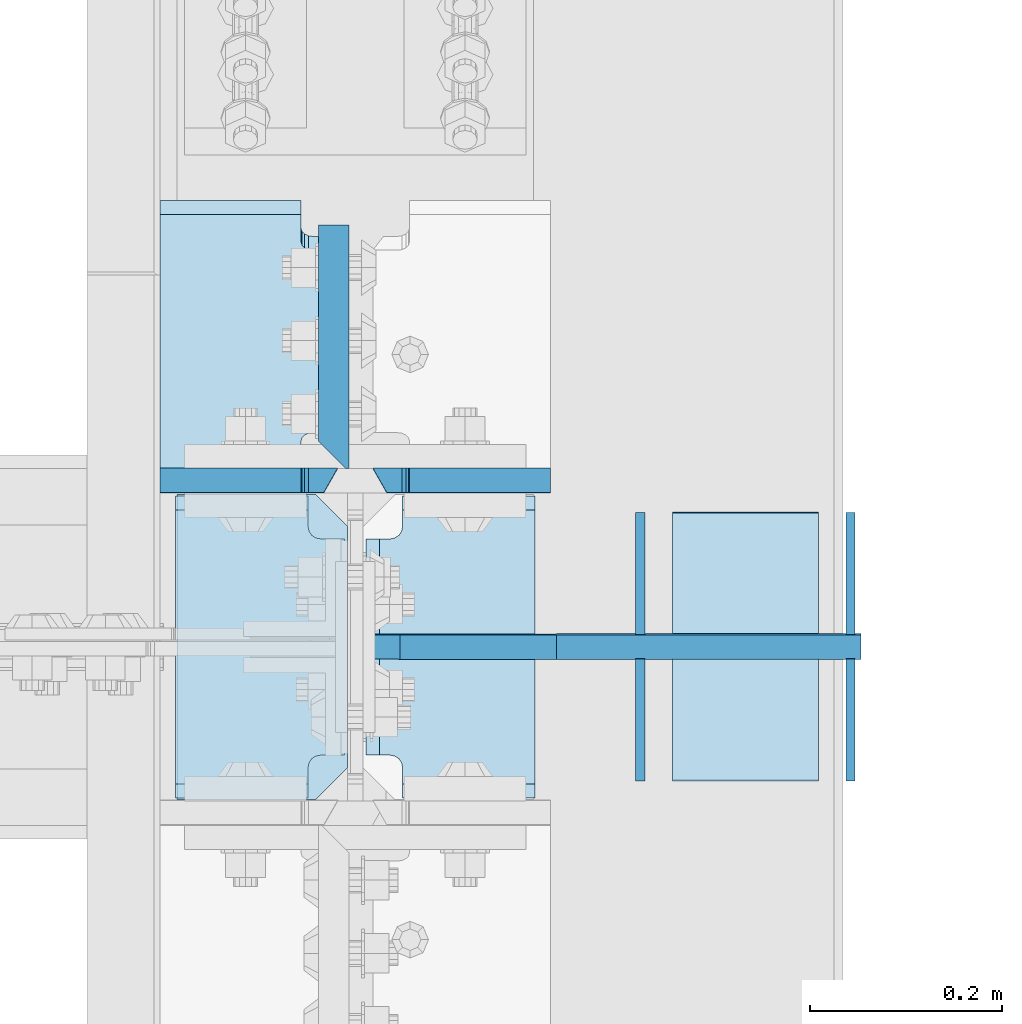
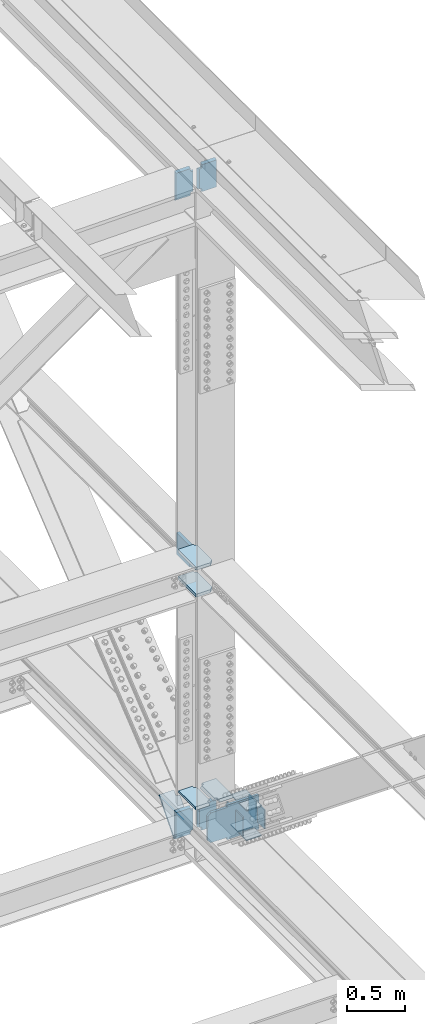
# One storey, part 3607 of 3843: 19 plates, 11 elements without a shape of their own.
"""IFC2X3 building model written with IfcOpenShell, lengths in millimetres."""

from ifc_helpers import new_model, si_unit, frame, origin_with_axes, place, context, subcontext, project, spatial, faceted_brep, material, type_object, element, aggregate, save


model = new_model("IFC2X3")

# Units and contexts
model_context = context("Model", 3, precision=1e-05, world=origin_with_axes())
body_context = subcontext(model_context, "Body", "Model", "MODEL_VIEW")
ifc_project = project(units=[si_unit("LENGTHUNIT", "METRE", prefix="MILLI"), si_unit("AREAUNIT", "SQUARE_METRE"), si_unit("VOLUMEUNIT", "CUBIC_METRE"), si_unit("MASSUNIT", "GRAM", prefix="KILO"), si_unit("TIMEUNIT", "SECOND"), si_unit("PLANEANGLEUNIT", "RADIAN"), si_unit("SOLIDANGLEUNIT", "STERADIAN"), si_unit("THERMODYNAMICTEMPERATUREUNIT", "DEGREE_CELSIUS"), si_unit("LUMINOUSINTENSITYUNIT", "LUMEN")], contexts=[model_context])

# Site, building, storey
site_placement = place(None, origin_with_axes())
site = spatial("IfcSite", under=ifc_project, at=site_placement, CompositionType="ELEMENT")
building_placement = place(site_placement, origin_with_axes())
building = spatial("IfcBuilding", under=site, at=building_placement, Name="Undefined", CompositionType="ELEMENT")
storey_placement = place(building_placement, origin_with_axes())
storey = spatial("IfcBuildingStorey", under=building, at=storey_placement, Name="Undefined", CompositionType="ELEMENT", Elevation=0.0)

# Assembly, plates
assembly_1_placement = place(storey_placement, origin_with_axes())
assembly_1 = element("IfcElementAssembly", 1, at=assembly_1_placement, inside=storey, Name="BEAM", AssemblyPlace="NOTDEFINED", PredefinedType="RIGID_FRAME")
ifc_material = material(Name="STEEL/A572-50")
plate_type_1 = type_object("IfcPlateType", PredefinedType="NOTDEFINED")
plate_1_placement = place(assembly_1_placement, frame((85852.0, 59089.2378498692, 46167.6104908396), z_axis=(0.0, -0.000625967000050877, 0.999999804082638), x_axis=(-1.0, 0.0, 0.0)))
plate_1 = element("IfcPlate", 2, at=plate_1_placement, type_object=plate_type_1, material=ifc_material, Name="PLATE", context=body_context, shape_type="Brep", body=[
    faceted_brep([(146.843749999985, -12.7000000009139, 314.306526230976), (146.843749999985, 12.6999999991967, 299.815034475985), (0.0, 12.6999999991967, 299.815034475985), (0.0, -12.7000000009139, 314.306526230976), (146.843749999985, 12.7000000000553, 14.4914917584392), (146.843749999985, -12.7000000000844, 2.18278728425503e-11), (0.0, -12.6999999999971, 0.0), (0.0, 12.7000000000698, 14.4914917390415), (146.843749999985, 12.6999999999098, 38.1890602041385), (146.843749999985, -12.7000000001572, 38.1003132816259), (147.810479922569, 12.6999999998952, 43.0491693876829), (147.810479922569, -12.7000000001644, 42.9604224651703), (150.563493823051, 12.6999999998734, 47.169371005024), (150.563493823051, -12.7000000001863, 47.0806240825113), (154.683670291211, 12.6999999998734, 49.9224017096567), (154.683670291211, -12.7000000001935, 49.833654787144), (159.543749809251, 12.6999999998661, 50.8891375330786), (159.543749809251, -12.7000000001935, 50.800390610566), (170.452258242993, 12.700000000099, 50.8891375249077), (184.943749999991, -12.7000000000116, 50.8003906183731), (184.943749999991, -12.6999999997643, 263.417469235843), (170.452258242993, 12.7000000003609, 263.506216142385), (159.543749809251, 12.6999999992186, 263.506216155103), (159.543749809251, -12.7000000008484, 263.417469232591), (154.683670291211, 12.6999999992113, 264.472951978518), (154.683670291211, -12.7000000008557, 264.384205056005), (150.563493823051, 12.699999999204, 267.225982683158), (150.563493823051, -12.7000000008629, 267.137235760645), (147.810479922569, 12.6999999991895, 271.346184300499), (147.810479922569, -12.7000000008702, 271.257437377986), (146.843749999985, 12.6999999991749, 276.206293484036), (146.843749999985, -12.7000000008848, 276.117546561523)], [[[0, 1, 2, 3]], [[4, 5, 6, 7]], [[8, 9, 5, 4]], [[9, 8, 10, 11]], [[11, 10, 12, 13]], [[13, 12, 14, 15]], [[15, 14, 16, 17]], [[17, 16, 18, 19]], [[20, 19, 18, 21]], [[22, 23, 20, 21]], [[23, 22, 24, 25]], [[25, 24, 26, 27]], [[27, 26, 28, 29]], [[29, 28, 30, 31]], [[6, 5, 9, 11, 13, 15, 17, 19, 20, 23, 25, 27, 29, 31, 0, 3]], [[7, 6, 3, 2]], [[30, 28, 26, 24, 22, 21, 18, 16, 14, 12, 10, 8, 4, 7, 2, 1]], [[31, 30, 1, 0]]]),
])
plate_2_placement = place(assembly_1_placement, frame((85630.54375, 59089.2378498698, 46167.6104908396), z_axis=(0.0, -0.000625967000050877, 0.999999804082638), x_axis=(-1.0, 0.0, 0.0)))
plate_2 = element("IfcPlate", 3, at=plate_2_placement, type_object=plate_type_1, material=ifc_material, Name="PLATE", context=body_context, shape_type="Brep", body=[
    faceted_brep([(184.943749999991, 12.6999999999316, 14.4914917581264), (184.943749999991, -12.6999999999607, -2.91038304567337e-11), (38.1000000000058, -12.7000000000844, 2.18278728425503e-11), (38.1000000000058, 12.7000000000553, 14.4914917584392), (37.1332700774219, -12.7000000001644, 42.9604224651848), (37.1332700774219, 12.6999999998952, 43.0491693876975), (38.1000000000058, 12.6999999999098, 38.1890602041531), (38.1000000000058, -12.7000000001572, 38.1003132816404), (34.3802561769407, -12.7000000001863, 47.0806240825259), (34.3802561769407, 12.6999999998734, 47.1693710050386), (30.2600797087798, -12.7000000001935, 49.8336547871586), (30.2600797087798, 12.6999999998734, 49.9224017096712), (25.4000001907407, -12.7000000001935, 50.8003906105805), (25.4000001907407, 12.6999999998661, 50.8891375330932), (0.0, -12.7000000000262, 50.8003906045633), (14.4914917569986, 12.7000000001135, 50.8891375364256), (14.4914917569986, 12.7000000003463, 263.506216154878), (0.0, -12.6999999997643, 263.417469223023), (25.4000001907407, -12.7000000008484, 263.417469232605), (25.4000001907407, 12.6999999992186, 263.506216155118), (30.2600797087798, -12.7000000008557, 264.38420505602), (30.2600797087798, 12.6999999992113, 264.472951978532), (34.3802561769407, -12.7000000008629, 267.13723576066), (34.3802561769407, 12.699999999204, 267.225982683172), (37.1332700774219, -12.7000000008702, 271.257437378001), (37.1332700774219, 12.6999999991895, 271.346184300513), (38.1000000000058, -12.7000000008848, 276.117546561538), (38.1000000000058, 12.6999999991749, 276.206293484051), (38.1000000000058, -12.6996899253718, 314.217780397244), (38.1000000000058, 12.6999999991167, 299.816846860216), (184.943749999991, -12.7000000008702, 314.308338618255), (184.943749999991, 12.6999999991167, 299.816846860216)], [[[0, 1, 2, 3]], [[4, 5, 6, 7]], [[8, 9, 5, 4]], [[10, 11, 9, 8]], [[12, 13, 11, 10]], [[13, 12, 14, 15]], [[16, 15, 14, 17]], [[18, 19, 16, 17]], [[20, 21, 19, 18]], [[22, 23, 21, 20]], [[24, 25, 23, 22]], [[26, 27, 25, 24]], [[27, 26, 28, 29]], [[30, 31, 29, 28]], [[6, 5, 9, 11, 13, 15, 16, 19, 21, 23, 25, 27, 29, 31, 0, 3]], [[7, 6, 3, 2]], [[30, 28, 26, 24, 22, 20, 18, 17, 14, 12, 10, 8, 4, 7, 2, 1]], [[31, 30, 1, 0]]]),
])
aggregate(assembly_1, [plate_1, plate_2])

assembly_2_placement = place(storey_placement, origin_with_axes())
assembly_2 = element("IfcElementAssembly", 4, at=assembly_2_placement, inside=storey, Name="BEAM", AssemblyPlace="NOTDEFINED", PredefinedType="RIGID_FRAME")
plate_3_placement = place(assembly_2_placement, frame((85852.0, 59088.6039173577, 39404.9158835514), z_axis=(0.0, -0.000749054000341859, 0.999999719459013), x_axis=(-1.0, 0.0, 0.0)))
plate_3 = element("IfcPlate", 5, at=plate_3_placement, type_object=plate_type_1, material=ifc_material, Name="PLATE", context=body_context, shape_type="Brep", body=[
    faceted_brep([(146.843749999985, -12.6999999998079, 304.780308140878), (146.843749999985, 12.7000000002299, 290.288816385233), (0.0, 12.7000000002299, 290.288816385233), (0.0, -12.6999999998079, 304.780308140878), (146.843749999985, 12.7000000000553, 14.4914917584392), (146.843749999985, -12.7000000000844, 2.18278728425503e-11), (0.0, -12.6999999999971, 0.0), (0.0, 12.7000000000698, 14.4914917390415), (146.843749999985, 12.6999999999098, 38.1890602041385), (146.843749999985, -12.7000000001572, 38.1003132816259), (147.810479922569, 12.6999999998952, 43.0491693876829), (147.810479922569, -12.7000000001644, 42.9604224651703), (150.563493823051, 12.6999999998734, 47.169371005024), (150.563493823051, -12.7000000001863, 47.0806240825113), (154.683670291211, 12.6999999998734, 49.9224017096567), (154.683670291211, -12.7000000001935, 49.833654787144), (159.543749809251, 12.6999999998661, 50.8891375330786), (159.543749809251, -12.7000000001935, 50.800390610566), (170.452258242993, 12.700000000099, 50.8891375249077), (184.943749999991, -12.7000000000116, 50.8003906183731), (184.943749999991, -12.6999999997643, 263.417469235843), (170.452258242993, 12.7000000003609, 263.506216142385), (159.543749809251, 12.6999999992186, 263.506216155103), (159.543749809251, -12.7000000008484, 263.417469232591), (154.683670291211, 12.6999999992113, 264.472951978518), (154.683670291211, -12.7000000008557, 264.384205056005), (150.563493823051, 12.699999999204, 267.225982683158), (150.563493823051, -12.7000000008629, 267.137235760645), (147.810479922569, 12.6999999991895, 271.346184300499), (147.810479922569, -12.7000000008702, 271.257437377986), (146.843749999985, 12.6999999991749, 276.206293484036), (146.843749999985, -12.7000000008848, 276.117546561523)], [[[0, 1, 2, 3]], [[4, 5, 6, 7]], [[8, 9, 5, 4]], [[9, 8, 10, 11]], [[11, 10, 12, 13]], [[13, 12, 14, 15]], [[15, 14, 16, 17]], [[17, 16, 18, 19]], [[20, 19, 18, 21]], [[22, 23, 20, 21]], [[23, 22, 24, 25]], [[25, 24, 26, 27]], [[27, 26, 28, 29]], [[29, 28, 30, 31]], [[6, 5, 9, 11, 13, 15, 17, 19, 20, 23, 25, 27, 29, 31, 0, 3]], [[7, 6, 3, 2]], [[30, 28, 26, 24, 22, 21, 18, 16, 14, 12, 10, 8, 4, 7, 2, 1]], [[31, 30, 1, 0]]]),
])
plate_4_placement = place(assembly_2_placement, frame((85630.54375, 59088.6039173577, 39404.9158835514), z_axis=(0.0, -0.000749054000341859, 0.999999719459013), x_axis=(-1.0, 0.0, 0.0)))
plate_4 = element("IfcPlate", 6, at=plate_4_placement, type_object=plate_type_1, material=ifc_material, Name="PLATE", context=body_context, shape_type="Brep", body=[
    faceted_brep([(184.943749999991, 12.6999999999316, 14.4914917581264), (184.943749999991, -12.6999999999607, -2.91038304567337e-11), (38.1000000000058, -12.7000000000844, 2.18278728425503e-11), (38.1000000000058, 12.7000000000553, 14.4914917584392), (37.1332700774219, -12.7000000001644, 42.9604224651848), (37.1332700774219, 12.6999999998952, 43.0491693876975), (38.1000000000058, 12.6999999999098, 38.1890602041531), (38.1000000000058, -12.7000000001572, 38.1003132816404), (34.3802561769407, -12.7000000001863, 47.0806240825259), (34.3802561769407, 12.6999999998734, 47.1693710050386), (30.2600797087798, -12.7000000001935, 49.8336547871586), (30.2600797087798, 12.6999999998734, 49.9224017096712), (25.4000001907407, -12.7000000001935, 50.8003906105805), (25.4000001907407, 12.6999999998661, 50.8891375330932), (0.0, -12.7000000000262, 50.8003906045633), (14.4914917569986, 12.7000000001135, 50.8891375364256), (14.4914917569986, 12.7000000003463, 263.506216154878), (0.0, -12.6999999997643, 263.417469223023), (25.4000001907407, -12.7000000008484, 263.417469232605), (25.4000001907407, 12.6999999992186, 263.506216155118), (30.2600797087798, -12.7000000008557, 264.38420505602), (30.2600797087798, 12.6999999992113, 264.472951978532), (34.3802561769407, -12.7000000008629, 267.13723576066), (34.3802561769407, 12.699999999204, 267.225982683172), (37.1332700774219, -12.7000000008702, 271.257437378001), (37.1332700774219, 12.6999999991895, 271.346184300513), (38.1000000000058, -12.7000000008848, 276.117546561538), (38.1000000000058, 12.6999999991749, 276.206293484051), (38.1000000000058, -12.6999999998079, 304.780308140878), (38.1000000000058, 12.7000000002299, 290.288816385233), (184.943749999991, -12.6999999998079, 304.780308140878), (184.943749999991, 12.7000000002299, 290.288816385233)], [[[0, 1, 2, 3]], [[4, 5, 6, 7]], [[8, 9, 5, 4]], [[10, 11, 9, 8]], [[12, 13, 11, 10]], [[13, 12, 14, 15]], [[16, 15, 14, 17]], [[18, 19, 16, 17]], [[20, 21, 19, 18]], [[22, 23, 21, 20]], [[24, 25, 23, 22]], [[26, 27, 25, 24]], [[27, 26, 28, 29]], [[30, 31, 29, 28]], [[6, 5, 9, 11, 13, 15, 16, 19, 21, 23, 25, 27, 29, 31, 0, 3]], [[7, 6, 3, 2]], [[30, 28, 26, 24, 22, 20, 18, 17, 14, 12, 10, 8, 4, 7, 2, 1]], [[31, 30, 1, 0]]]),
])
plate_type_2 = type_object("IfcPlateType", PredefinedType="NOTDEFINED")
plate_5_placement = place(assembly_2_placement, frame((85633.71875, 59373.1905821127, 39705.1654637628), z_axis=(0.0, -0.653306260903701, -0.757093738888406), x_axis=(-1.0, 0.0, 0.0)))
plate_5 = element("IfcPlate", 7, at=plate_5_placement, type_object=plate_type_2, material=ifc_material, Name="PLATE", context=body_context, shape_type="Brep", body=[
    faceted_brep([(14.2875061034865, 9.52500000006694, 57.1797925277933), (3.17500610348361, -9.52501254876552, 57.1207040893933), (3.17500610348361, -9.52499999944121, 347.969537783152), (14.2875061034865, 9.52500000052532, 348.028626182626), (28.5750062942243, -9.52501325386038, 57.1207040872105), (28.5750062942243, 9.52500000006694, 57.1797925277933), (33.4350858122634, 9.52500000006694, 56.2130579548248), (33.4350858122634, -9.52501347736325, 56.1539695135434), (37.5552622804244, 9.52500000005602, 53.460030811184), (37.5552622804244, -9.52501384404604, 53.4009423687676), (40.3082761809055, 9.52500000005239, 49.3398345232417), (40.3082761809055, -9.52501429806216, 49.2807460794138), (41.2750061034894, 9.52500000004511, 44.4797316261684), (41.2750061034894, -9.52501477031547, 44.4206431808852), (41.2750061034894, 9.52499999996871, -1.45519152283669e-11), (41.2750000000087, -9.52499999999782, -7.27595761418343e-11), (188.118743896484, 9.52499999996871, -1.45519152283669e-11), (188.118743896484, -9.5249999999869, 1.45519152283669e-11), (188.118743896484, -9.52499999935389, 405.149356901587), (188.118743896484, 9.52500000062355, 405.149356901558), (41.2750061034894, 9.52500000062355, 405.149356901558), (41.2750061034894, -9.52490836140714, 405.119812982695), (41.2750061034894, 9.52500000054715, 360.728687084265), (41.2750061034894, -9.52499999942665, 360.669598684777), (40.3082761809055, 9.52500000053988, 355.868584187177), (40.3082761809055, -9.52499999942665, 355.809495787704), (37.5552622804244, 9.52500000053624, 351.748387899235), (37.5552622804244, -9.52499999943393, 351.689299499762), (33.4350858122634, 9.52500000052532, 348.995360755594), (33.4350858122634, -9.52499999944484, 348.936272356121), (28.5750062942243, 9.52500000052532, 348.028626182626), (28.5750062942243, -9.52499999944121, 347.969537783152)], [[[0, 1, 2, 3]], [[4, 5, 6, 7]], [[7, 6, 8, 9]], [[9, 8, 10, 11]], [[11, 10, 12, 13]], [[13, 12, 14, 15]], [[16, 17, 15, 14]], [[18, 17, 16, 19]], [[18, 19, 20, 21]], [[21, 20, 22, 23]], [[23, 22, 24, 25]], [[25, 24, 26, 27]], [[27, 26, 28, 29]], [[29, 28, 30, 31]], [[4, 7, 9, 11, 13, 15, 17, 18, 21, 23, 25, 27, 29, 31, 2, 1]], [[5, 4, 1, 0]], [[30, 28, 26, 24, 22, 20, 19, 16, 14, 12, 10, 8, 6, 5, 0, 3]], [[31, 30, 3, 2]]]),
])

assembly_3_placement = place(storey_placement, origin_with_axes())
assembly_3 = element("IfcElementAssembly", 8, at=assembly_3_placement, inside=storey, Name="COLUMN", AssemblyPlace="NOTDEFINED", PredefinedType="RIGID_FRAME")
plate_type_3 = type_object("IfcPlateType", PredefinedType="NOTDEFINED")
plate_6_placement = place(assembly_3_placement, frame((85463.0625000139, 59074.0500985465, 42180.1589123018), z_axis=(0.0, -1.0, 0.0), x_axis=(1.0, 0.0, 0.0)))
plate_6 = element("IfcPlate", 9, at=plate_6_placement, type_object=plate_type_3, material=ifc_material, Name="PLATE", context=body_context, shape_type="Brep", body=[
    faceted_brep([(0.0, -15.875, 0.0), (0.0, -15.875, 317.5), (0.0, 15.875, 317.5), (0.0, 15.875, 0.0), (144.462498511086, -15.874999999156, 317.499999999665), (144.462498511086, 15.875000000844, 317.499999999578), (177.800000033079, -15.8749999992506, 284.162498473786), (177.800000033079, 15.8750000007494, 284.162498473699), (177.800000003888, -15.8749999999054, 33.3375015259226), (177.800000003888, 15.8750000000946, 33.3375015258353), (144.462498474124, -15.875, 0.0), (144.462498474124, 15.875, 0.0)], [[[0, 1, 2, 3]], [[1, 4, 5, 2]], [[4, 6, 7, 5]], [[6, 8, 9, 7]], [[8, 10, 11, 9]], [[10, 0, 3, 11]], [[5, 7, 9, 11, 3, 2]], [[10, 8, 6, 4, 1, 0]]]),
])
plate_7_placement = place(assembly_3_placement, frame((85463.0625000139, 59074.0500902592, 42465.909280421), z_axis=(0.0, -1.0, 0.0), x_axis=(1.0, 0.0, 0.0)))
plate_7 = element("IfcPlate", 10, at=plate_7_placement, type_object=plate_type_3, material=ifc_material, Name="PLATE", context=body_context, shape_type="Brep", body=[
    faceted_brep([(0.0, -15.875, 0.0), (0.0, -15.875, 317.5), (0.0, 15.875, 317.5), (0.0, 15.875, 0.0), (144.462498511086, -15.874999999156, 317.499999999665), (144.462498511086, 15.875000000844, 317.499999999578), (177.800000033079, -15.8749999992506, 284.162498473786), (177.800000033079, 15.8750000007494, 284.162498473699), (177.800000003888, -15.8749999999054, 33.3375015259226), (177.800000003888, 15.8750000000946, 33.3375015258353), (144.462498474124, -15.875, 0.0), (144.462498474124, 15.875, 0.0)], [[[0, 1, 2, 3]], [[1, 4, 5, 2]], [[4, 6, 7, 5]], [[6, 8, 9, 7]], [[8, 10, 11, 9]], [[10, 0, 3, 11]], [[5, 7, 9, 11, 3, 2]], [[10, 8, 6, 4, 1, 0]]]),
])

# Plate
plate_type_4 = type_object("IfcPlateType", PredefinedType="NOTDEFINED")
plate_8_placement = place(assembly_2_placement, frame((86175.8500000045, 58916.4815932076, 39368.4273981063), z_axis=(0.0, -0.00349395200045545, 0.999993896131081), x_axis=(-1.0, 0.0, 0.0)))
plate_8 = element("IfcPlate", 11, at=plate_8_placement, type_object=plate_type_4, material=ifc_material, Name="STIFFENER", context=body_context, shape_type="Brep", body=[
    faceted_brep([(0.0, -12.6999999999971, 0.0), (1.43627403303981e-08, -12.7000000003172, 368.282421855467), (1.43627403303981e-08, 12.6999999996769, 368.282421855489), (0.0, 12.6999999999971, 0.0), (317.500000026223, -12.7000000003172, 368.282421839234), (317.500000026223, 12.6999999996769, 368.282421839256), (317.500000024767, -12.7000000002881, 342.88242181766), (317.500000024767, 12.6999999996915, 342.882421817681), (480.218749970372, -12.7000000002881, 342.882421787188), (480.218749970372, 12.6999999996915, 342.88242178721), (511.968749969019, -12.700000000259, 311.132421781258), (511.968749969019, 12.6999999997206, 311.132421781287), (511.968749958221, -12.7000000000553, 57.1500000187953), (511.968749958221, 12.6999999999389, 57.1500000188171), (480.218749956868, -12.7000000000116, 25.4000000166852), (480.218749956868, 12.6999999999825, 25.4000000167216), (317.500000000146, -12.7000000000116, 25.4000000058295), (317.500000000146, 12.699999999968, 25.4000000058659), (317.50000000211, -12.6999999999971, -8.14907252788544e-10), (317.50000000211, 12.6999999999971, -7.93079379945993e-10)], [[[0, 1, 2, 3]], [[1, 4, 5, 2]], [[4, 6, 7, 5]], [[6, 8, 9, 7]], [[8, 10, 11, 9]], [[10, 12, 13, 11]], [[12, 14, 15, 13]], [[14, 16, 17, 15]], [[16, 18, 19, 17]], [[18, 0, 3, 19]], [[5, 7, 9, 11, 13, 15, 17, 19, 3, 2]], [[18, 16, 14, 12, 10, 8, 6, 4, 1, 0]]]),
])

plate_type_5 = type_object("IfcPlateType", PredefinedType="NOTDEFINED")
plate_9_placement = place(assembly_3_placement, frame((85626.575, 59101.0375910967, 42436.8775105528), z_axis=(0.0, 1.0, 0.0), x_axis=(0.0, 0.0, -1.0)))
plate_9 = element("IfcPlate", 12, at=plate_9_placement, type_object=plate_type_5, material=ifc_material, Name="PLATE", context=body_context, shape_type="Brep", body=[
    faceted_brep([(228.600000000064, 15.875, 28.5750007623283), (228.599999999991, -12.7000007629103, -5.82076609134674e-10), (0.0, -12.6999999999971, 0.0), (6.54836185276508e-11, 15.875, 28.5750007629249), (0.0, -15.875, 0.0), (6.69388100504875e-10, -15.875, 254.0), (6.69388100504875e-10, 15.875, 254.0), (228.600000000668, -15.875, 253.999999999403), (228.600000000668, 15.875, 253.999999999403), (228.599999999991, -15.875, -5.82076609134674e-10)], [[[0, 1, 2, 3]], [[4, 5, 6, 3, 2]], [[5, 7, 8, 6]], [[8, 7, 9, 1, 0]], [[9, 4, 2, 1]], [[6, 8, 0, 3]], [[9, 7, 5, 4]]]),
])

aggregate(assembly_3, [plate_9, plate_6, plate_7])

plate_type_6 = type_object("IfcPlateType", PredefinedType="NOTDEFINED")
plate_10_placement = place(assembly_2_placement, frame((85461.475, 58758.1375343957, 39922.4078874334), z_axis=(0.0, 1.0, 0.0), x_axis=(1.0, 0.0, 0.0)))
plate_10 = element("IfcPlate", 13, at=plate_10_placement, type_object=plate_type_6, material=ifc_material, Name="PLATE", context=body_context, shape_type="Brep", body=[
    faceted_brep([(138.112998474113, 12.7000000004045, 314.324999999983), (0.0, 12.7000000004045, 314.324999999983), (0.0, -12.6999999996187, 299.83350824329), (138.112998474113, -12.6999999996187, 299.83350824329), (138.112998474113, -12.6999999999825, 14.4914917567294), (0.0, -12.7000000000771, 14.4914917543283), (0.0, 12.6999999999971, 0.0), (138.112998474113, 12.6999999999898, -7.27595761418343e-12), (138.112998474113, 12.7000000000335, 31.7641602857766), (138.112998474113, -12.699999999968, 31.7641626480399), (139.079728396697, 12.7000000000407, 36.624239803823), (139.079728396697, -12.6999999999534, 36.6242421660863), (141.832742297178, 12.700000000048, 40.7444162719767), (141.832742297178, -12.6999999999534, 40.74441863424), (145.952918765339, 12.7000000000553, 43.4974301724505), (145.952918765339, -12.6999999999462, 43.4974325347212), (150.812998283378, 12.700000000048, 44.4641600950417), (150.812998283378, -12.6999999999462, 44.4641624573051), (176.212499999994, 12.700000000048, 44.4641600950417), (161.925498474113, -12.6999999999462, 44.4641624573051), (176.212499999994, 12.7000000003463, 269.875002362205), (161.925498474113, -12.6999999996551, 269.875000000007), (150.812998283378, 12.7000000003463, 269.875002362205), (150.812998283378, -12.6999999996551, 269.875000000007), (145.952918765339, 12.7000000003391, 270.841732284796), (145.952918765339, -12.6999999996551, 270.841729922598), (141.832742297178, 12.7000000003463, 273.59474618527), (141.832742297178, -12.6999999996478, 273.594743823072), (139.079728396697, 12.7000000003536, 277.714922653424), (139.079728396697, -12.6999999996478, 277.714920291226), (138.112998474113, 12.7000000003609, 282.57500217147), (138.112998474113, -12.6999999996406, 282.574999809272)], [[[0, 1, 2, 3]], [[4, 5, 6, 7]], [[8, 9, 4, 7]], [[9, 8, 10, 11]], [[11, 10, 12, 13]], [[13, 12, 14, 15]], [[15, 14, 16, 17]], [[17, 16, 18, 19]], [[19, 18, 20, 21]], [[22, 23, 21, 20]], [[23, 22, 24, 25]], [[25, 24, 26, 27]], [[27, 26, 28, 29]], [[29, 28, 30, 31]], [[31, 30, 0, 3]], [[5, 4, 9, 11, 13, 15, 17, 19, 21, 23, 25, 27, 29, 31, 3, 2]], [[6, 5, 2, 1]], [[30, 28, 26, 24, 22, 20, 18, 16, 14, 12, 10, 8, 7, 6, 1, 0]]]),
])

plate_11_placement = place(assembly_2_placement, frame((85659.9125, 58758.1375343957, 39922.4078874334), z_axis=(0.0, 1.0, 0.0), x_axis=(1.0, 0.0, 0.0)))
plate_11 = element("IfcPlate", 14, at=plate_11_placement, type_object=plate_type_6, material=ifc_material, Name="PLATE", context=body_context, shape_type="Brep", body=[
    faceted_brep([(176.212499999994, -12.6999999999825, 14.4914917567367), (38.0995015258814, -12.6999999999825, 14.4914917567367), (38.0995015258814, 12.6999999999898, -7.27595761418343e-12), (176.212499999994, 12.6999999999898, -7.27595761418343e-12), (37.1327716032974, -12.6999999999534, 36.6242421660936), (37.1327716032974, 12.7000000000407, 36.6242398038303), (38.0995015258814, 12.7000000000335, 31.7641602857839), (38.0995015258814, -12.699999999968, 31.7641626480472), (34.3797577028163, -12.6999999999534, 40.7444186342473), (34.3797577028163, 12.700000000048, 40.7444162719839), (30.2595812346553, -12.6999999999462, 43.4974325347284), (30.2595812346553, 12.7000000000553, 43.4974301724578), (25.3995017166162, -12.6999999999462, 44.4641624573123), (25.3995017166162, 12.700000000048, 44.464160095049), (14.2875000000058, -12.6999999999462, 44.4641624573123), (0.0, 12.700000000048, 44.464160095049), (14.2875000000058, -12.6999999996551, 269.875000000015), (0.0, 12.7000000003463, 269.875002362212), (25.3995017166162, -12.6999999996551, 269.875000000015), (25.3995017166162, 12.7000000003463, 269.875002362212), (30.2595812346553, -12.6999999996551, 270.841729922606), (30.2595812346553, 12.7000000003391, 270.841732284804), (34.3797577028163, -12.6999999996478, 273.59474382308), (34.3797577028163, 12.7000000003463, 273.594746185277), (37.1327716032974, -12.6999999996478, 277.714920291233), (37.1327716032974, 12.7000000003536, 277.714922653431), (38.0995015258814, -12.6999999996406, 282.57499980928), (38.0995015258814, 12.7000000003609, 282.575002171478), (38.0995015258814, -12.6999999996187, 299.833508243297), (38.0995015258814, 12.7000000004045, 314.324999999983), (176.212499999994, 12.7000000004045, 314.324999999983), (176.212499999994, -12.6999999996187, 299.833508243297)], [[[0, 1, 2, 3]], [[4, 5, 6, 7]], [[8, 9, 5, 4]], [[10, 11, 9, 8]], [[12, 13, 11, 10]], [[13, 12, 14, 15]], [[15, 14, 16, 17]], [[18, 19, 17, 16]], [[20, 21, 19, 18]], [[22, 23, 21, 20]], [[24, 25, 23, 22]], [[26, 27, 25, 24]], [[27, 26, 28, 29]], [[30, 29, 28, 31]], [[30, 31, 0, 3]], [[6, 5, 9, 11, 13, 15, 17, 19, 21, 23, 25, 27, 29, 30, 3, 2]], [[7, 6, 2, 1]], [[31, 28, 26, 24, 22, 20, 18, 16, 14, 12, 10, 8, 4, 7, 1, 0]]]),
])

aggregate(assembly_2, [plate_5, plate_8, plate_3, plate_4, plate_10, plate_11])

# Assembly, plate
assembly_4_placement = place(storey_placement, origin_with_axes())
assembly_4 = element("IfcElementAssembly", 15, at=assembly_4_placement, inside=storey, Name="PLATE", AssemblyPlace="NOTDEFINED", PredefinedType="RIGID_FRAME")
plate_type_7 = type_object("IfcPlateType", PredefinedType="NOTDEFINED")
plate_12_placement = place(assembly_4_placement, frame((85945.6625, 58902.9551068088, 39655.7510426252), z_axis=(0.0, -0.999998474004818, -0.00174699400001555), x_axis=(0.0, 0.00174699400001411, -0.999998474004818)))
plate_12 = element("IfcPlate", 16, at=plate_12_placement, type_object=plate_type_7, material=ifc_material, Name="PLATE", context=body_context, shape_type="Brep", body=[
    faceted_brep([(0.0, -4.76249999999709, 0.0), (0.221868254287983, -4.76249999999709, 126.999806198757), (0.221868254287983, 4.76249999999709, 126.999806198757), (0.0, 4.76249999999709, 0.0), (203.421558172435, -4.76249999999709, 126.999806198277), (203.421558172435, 4.76249999999709, 126.999806198277), (203.199689918176, -4.76249999999709, -4.65661287307739e-10), (203.199689918176, 4.76249999999709, -4.65661287307739e-10)], [[[0, 1, 2, 3]], [[1, 4, 5, 2]], [[4, 6, 7, 5]], [[6, 0, 3, 7]], [[5, 7, 3, 2]], [[6, 4, 1, 0]]]),
])
aggregate(assembly_4, [plate_12])

assembly_5_placement = place(storey_placement, origin_with_axes())
assembly_5 = element("IfcElementAssembly", 17, at=assembly_5_placement, inside=storey, Name="PLATE", AssemblyPlace="NOTDEFINED", PredefinedType="RIGID_FRAME")
plate_13_placement = place(assembly_5_placement, frame((86164.7375000001, 58902.9551068086, 39655.751042625), z_axis=(0.0, -0.999998474004818, -0.00174699400001555), x_axis=(0.0, 0.00174699400001411, -0.999998474004818)))
plate_13 = element("IfcPlate", 18, at=plate_13_placement, type_object=plate_type_7, material=ifc_material, Name="PLATE", context=body_context, shape_type="Brep", body=[
    faceted_brep([(0.0, -4.76249999999709, 0.0), (0.221868254287983, -4.76249999999709, 126.999806198757), (0.221868254287983, 4.76249999999709, 126.999806198757), (0.0, 4.76249999999709, 0.0), (203.421558172435, -4.76249999999709, 126.999806198277), (203.421558172435, 4.76249999999709, 126.999806198277), (203.199689918176, -4.76249999999709, -4.65661287307739e-10), (203.199689918176, 4.76249999999709, -4.65661287307739e-10)], [[[0, 1, 2, 3]], [[1, 4, 5, 2]], [[4, 6, 7, 5]], [[6, 0, 3, 7]], [[5, 7, 3, 2]], [[6, 4, 1, 0]]]),
])
aggregate(assembly_5, [plate_13])

assembly_6_placement = place(storey_placement, origin_with_axes())
assembly_6 = element("IfcElementAssembly", 19, at=assembly_6_placement, inside=storey, Name="PLATE", AssemblyPlace="NOTDEFINED", PredefinedType="RIGID_FRAME")
plate_14_placement = place(assembly_6_placement, frame((86131.4000000045, 58903.6876649609, 39395.2881855176), z_axis=(0.0, -0.999993896022768, -0.00349398300008034), x_axis=(-1.0, 0.0, 0.0)))
plate_14 = element("IfcPlate", 20, at=plate_14_placement, type_object=plate_type_7, material=ifc_material, Name="PLATE", context=body_context, shape_type="Brep", body=[
    faceted_brep([(0.0, -4.76249999999709, 0.0), (-5.82076609134674e-11, -4.76249999972788, 126.999999995154), (-5.82076609134674e-11, 4.76250000024447, 126.999999995183), (0.0, 4.76249999999709, 0.0), (152.399999999951, -4.76249999972788, 126.999999995154), (152.399999999951, 4.76250000024447, 126.999999995183), (152.399993896484, -4.76249999999709, 0.0), (152.399993896484, 4.76249999999709, 0.0)], [[[0, 1, 2, 3]], [[1, 4, 5, 2]], [[4, 6, 7, 5]], [[6, 0, 3, 7]], [[5, 7, 3, 2]], [[6, 4, 1, 0]]]),
])
aggregate(assembly_6, [plate_14])

assembly_7_placement = place(storey_placement, origin_with_axes())
assembly_7 = element("IfcElementAssembly", 21, at=assembly_7_placement, inside=storey, Name="PLATE", AssemblyPlace="NOTDEFINED", PredefinedType="RIGID_FRAME")
plate_15_placement = place(assembly_7_placement, frame((86131.3999975899, 58902.5799909081, 39712.7863114402), z_axis=(0.0, -0.999993896022768, -0.00349398300008034), x_axis=(-1.0, 0.0, 0.0)))
plate_15 = element("IfcPlate", 22, at=plate_15_placement, type_object=plate_type_7, material=ifc_material, Name="PLATE", context=body_context, shape_type="Brep", body=[
    faceted_brep([(0.0, -4.76249999999709, 0.0), (-5.82076609134674e-11, -4.76249999972788, 126.999999995154), (-5.82076609134674e-11, 4.76250000024447, 126.999999995183), (0.0, 4.76249999999709, 0.0), (152.399999999951, -4.76249999972788, 126.999999995154), (152.399999999951, 4.76250000024447, 126.999999995183), (152.399993896484, -4.76249999999709, 0.0), (152.399993896484, 4.76249999999709, 0.0)], [[[0, 1, 2, 3]], [[1, 4, 5, 2]], [[4, 6, 7, 5]], [[6, 0, 3, 7]], [[5, 7, 3, 2]], [[6, 4, 1, 0]]]),
])
aggregate(assembly_7, [plate_15])

assembly_8_placement = place(storey_placement, origin_with_axes())
assembly_8 = element("IfcElementAssembly", 23, at=assembly_8_placement, inside=storey, Name="PLATE", AssemblyPlace="NOTDEFINED", PredefinedType="RIGID_FRAME")
plate_16_placement = place(assembly_8_placement, frame((85945.6625, 58928.3549042905, 39655.8541200381), z_axis=(0.0, 0.999998474031022, 0.00174697900004685), x_axis=(0.0, 0.00174699400001411, -0.999998474004818)))
plate_16 = element("IfcPlate", 24, at=plate_16_placement, type_object=plate_type_7, material=ifc_material, Name="PLATE", context=body_context, shape_type="Brep", body=[
    faceted_brep([(0.0, -4.76249999999709, 0.0), (-0.221866275547654, -4.76249999999709, 126.999806200889), (-0.221866275547654, 4.76249999999709, 126.999806200889), (0.0, 4.76249999999709, 0.0), (202.977823645364, -4.76249999999709, 126.999806202199), (202.977823645364, 4.76249999999709, 126.999806202199), (203.199689918176, -4.76249999999709, -4.65661287307739e-10), (203.199689918176, 4.76249999999709, -4.65661287307739e-10)], [[[0, 1, 2, 3]], [[1, 4, 5, 2]], [[4, 6, 7, 5]], [[6, 0, 3, 7]], [[5, 7, 3, 2]], [[6, 4, 1, 0]]]),
])
aggregate(assembly_8, [plate_16])

assembly_9_placement = place(storey_placement, origin_with_axes())
assembly_9 = element("IfcElementAssembly", 25, at=assembly_9_placement, inside=storey, Name="PLATE", AssemblyPlace="NOTDEFINED", PredefinedType="RIGID_FRAME")
plate_17_placement = place(assembly_9_placement, frame((86164.7375000001, 58928.3549042904, 39655.8541200378), z_axis=(0.0, 0.999998474031022, 0.00174697900004685), x_axis=(0.0, 0.00174699400001411, -0.999998474004818)))
plate_17 = element("IfcPlate", 26, at=plate_17_placement, type_object=plate_type_7, material=ifc_material, Name="PLATE", context=body_context, shape_type="Brep", body=[
    faceted_brep([(0.0, -4.76249999999709, 0.0), (-0.221866275547654, -4.76249999999709, 126.999806200889), (-0.221866275547654, 4.76249999999709, 126.999806200889), (0.0, 4.76249999999709, 0.0), (202.977823645364, -4.76249999999709, 126.999806202199), (202.977823645364, 4.76249999999709, 126.999806202199), (203.199689918176, -4.76249999999709, -4.65661287307739e-10), (203.199689918176, 4.76249999999709, -4.65661287307739e-10)], [[[0, 1, 2, 3]], [[1, 4, 5, 2]], [[4, 6, 7, 5]], [[6, 0, 3, 7]], [[5, 7, 3, 2]], [[6, 4, 1, 0]]]),
])
aggregate(assembly_9, [plate_17])

assembly_10_placement = place(storey_placement, origin_with_axes())
assembly_10 = element("IfcElementAssembly", 27, at=assembly_10_placement, inside=storey, Name="PLATE", AssemblyPlace="NOTDEFINED", PredefinedType="RIGID_FRAME")
plate_18_placement = place(assembly_10_placement, frame((86131.4000000045, 58929.0870874804, 39395.505075489), z_axis=(0.0, 0.999993896131081, 0.00349395200045545), x_axis=(-1.0, 0.0, 0.0)))
plate_18 = element("IfcPlate", 28, at=plate_18_placement, type_object=plate_type_7, material=ifc_material, Name="PLATE", context=body_context, shape_type="Brep", body=[
    faceted_brep([(0.0, -4.76249999999709, 0.0), (-5.82076609134674e-11, -4.76249999972788, 126.999999995154), (-5.82076609134674e-11, 4.76250000024447, 126.999999995183), (0.0, 4.76249999999709, 0.0), (152.399999999951, -4.76249999972788, 126.999999995154), (152.399999999951, 4.76250000024447, 126.999999995183), (152.399993896484, -4.76249999999709, 0.0), (152.399993896484, 4.76249999999709, 0.0)], [[[0, 1, 2, 3]], [[1, 4, 5, 2]], [[4, 6, 7, 5]], [[6, 0, 3, 7]], [[5, 7, 3, 2]], [[6, 4, 1, 0]]]),
])
aggregate(assembly_10, [plate_18])

assembly_11_placement = place(storey_placement, origin_with_axes())
assembly_11 = element("IfcElementAssembly", 29, at=assembly_11_placement, inside=storey, Name="PLATE", AssemblyPlace="NOTDEFINED", PredefinedType="RIGID_FRAME")
plate_19_placement = place(assembly_11_placement, frame((86131.3999975899, 58927.9777525507, 39713.0034611968), z_axis=(0.0, 0.999993896131081, 0.00349395200045545), x_axis=(-1.0, 0.0, 0.0)))
plate_19 = element("IfcPlate", 30, at=plate_19_placement, type_object=plate_type_7, material=ifc_material, Name="PLATE", context=body_context, shape_type="Brep", body=[
    faceted_brep([(0.0, -4.76249999999709, 0.0), (-5.82076609134674e-11, -4.76249999972788, 126.999999995154), (-5.82076609134674e-11, 4.76250000024447, 126.999999995183), (0.0, 4.76249999999709, 0.0), (152.399999999951, -4.76249999972788, 126.999999995154), (152.399999999951, 4.76250000024447, 126.999999995183), (152.399993896484, -4.76249999999709, 0.0), (152.399993896484, 4.76249999999709, 0.0)], [[[0, 1, 2, 3]], [[1, 4, 5, 2]], [[4, 6, 7, 5]], [[6, 0, 3, 7]], [[5, 7, 3, 2]], [[6, 4, 1, 0]]]),
])
aggregate(assembly_11, [plate_19])

save(model, "model.ifc")
